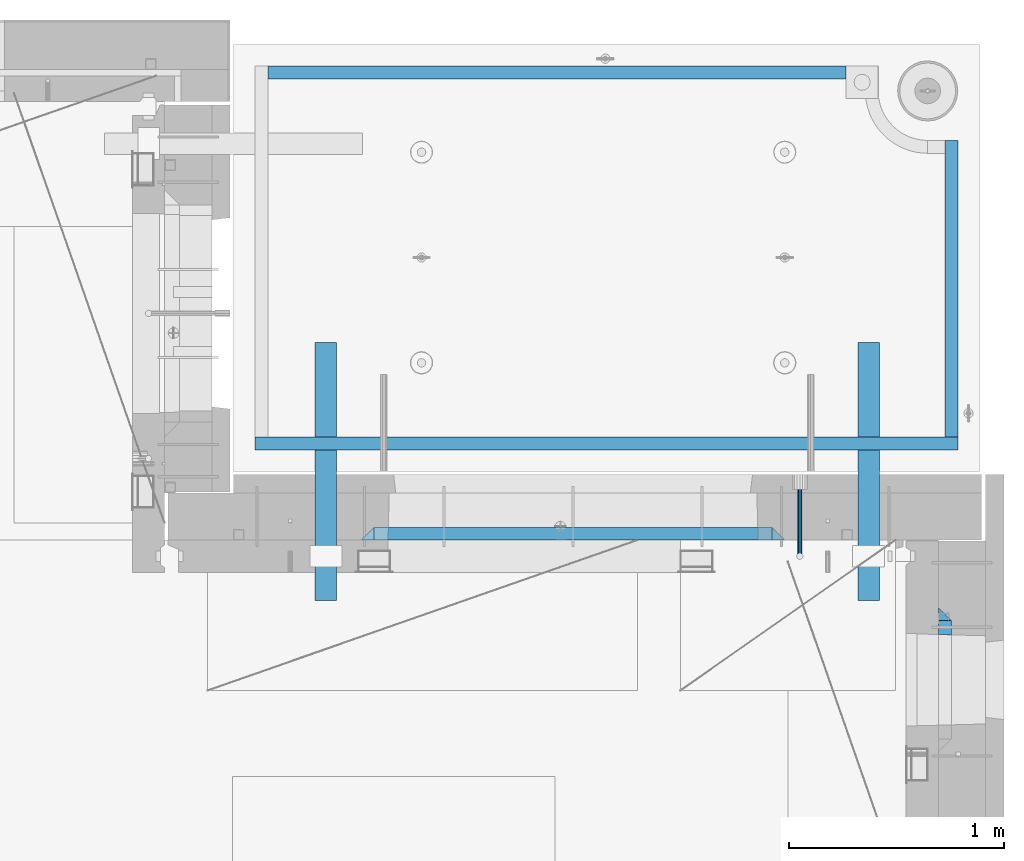
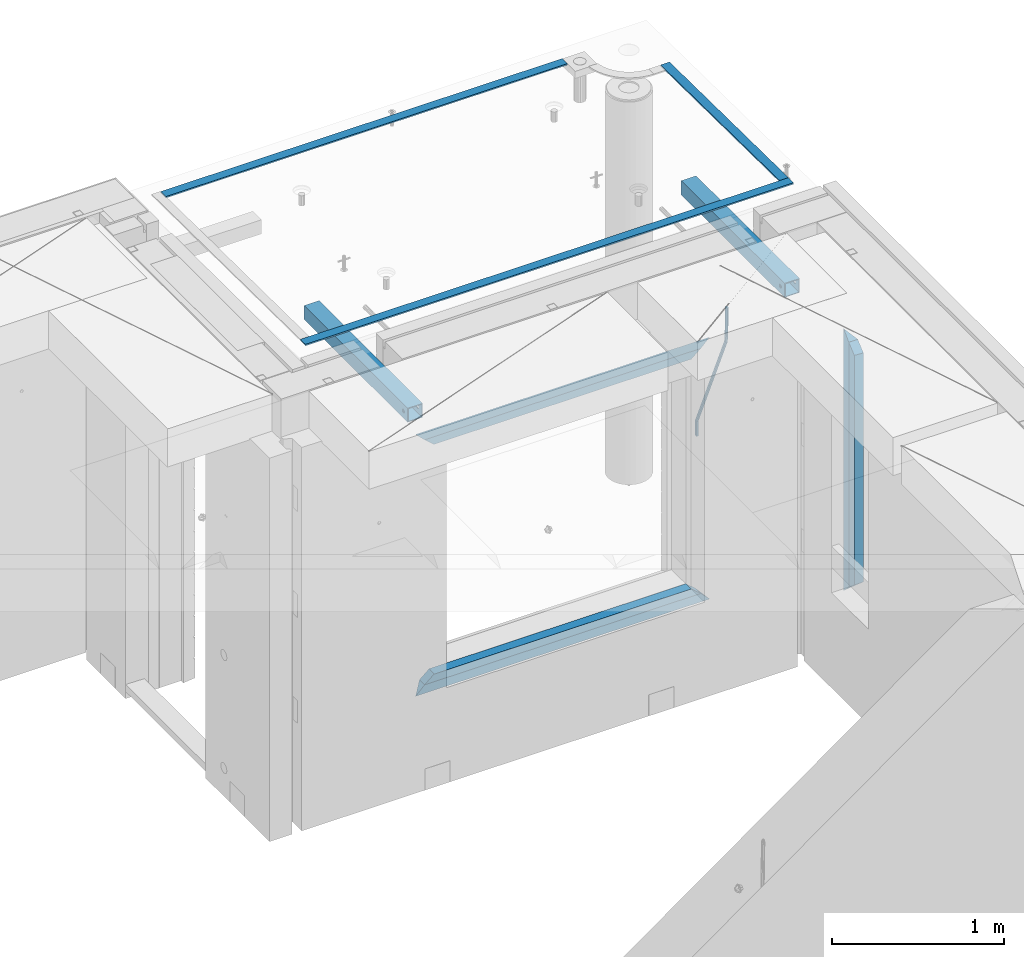
# One storey, part 135 of 349: 12 beams, 5 elements without a shape of their own.
"""IFC2X3 building model written with IfcOpenShell, lengths in millimetres."""

from ifc_helpers import new_model, si_unit, frame, origin_with_axes, place, context, subcontext, project, spatial, faceted_brep, material, type_object, element, aggregate, save


model = new_model("IFC2X3")

# Units and contexts
model_context = context("Model", 3, precision=1e-05, world=origin_with_axes())
body_context = subcontext(model_context, "Body", "Model", "MODEL_VIEW")
ifc_project = project(units=[si_unit("LENGTHUNIT", "METRE", prefix="MILLI"), si_unit("AREAUNIT", "SQUARE_METRE"), si_unit("VOLUMEUNIT", "CUBIC_METRE"), si_unit("MASSUNIT", "GRAM", prefix="KILO"), si_unit("TIMEUNIT", "SECOND"), si_unit("PLANEANGLEUNIT", "RADIAN"), si_unit("SOLIDANGLEUNIT", "STERADIAN"), si_unit("THERMODYNAMICTEMPERATUREUNIT", "DEGREE_CELSIUS"), si_unit("LUMINOUSINTENSITYUNIT", "LUMEN")], contexts=[model_context])

# Site, building, storey
site_placement = place(None, origin_with_axes())
site = spatial("IfcSite", under=ifc_project, at=site_placement, CompositionType="ELEMENT")
building_placement = place(site_placement, origin_with_axes())
building = spatial("IfcBuilding", under=site, at=building_placement, CompositionType="ELEMENT")
storey_placement = place(building_placement, origin_with_axes())
storey = spatial("IfcBuildingStorey", under=building, at=storey_placement, Name="4", CompositionType="ELEMENT", Elevation=0.0)

# Assembly, beam
assembly_1_placement = place(storey_placement, origin_with_axes())
assembly_1 = element("IfcElementAssembly", 1, at=assembly_1_placement, inside=storey, AssemblyPlace="NOTDEFINED", PredefinedType="REINFORCEMENT_UNIT")
ifc_material_1 = material()
beam_type_1 = type_object("IfcBeamType", Name="D20", PredefinedType="NOTDEFINED")
beam_1_placement = place(assembly_1_placement, frame((34415.0000001015, 20504.9951872346, 93407.5), z_axis=(0.000415599999849905, 0.999999913638203, 4.76000000899737e-07), x_axis=(0.0, 0.0, -1.0)))
beam_1 = element("IfcBeam", 2, at=beam_1_placement, type_object=beam_type_1, material=ifc_material_1, Name="JM20", ObjectType="D20", context=body_context, shape_type="Brep", body=[
    faceted_brep([(-0.00060564729210455, -9.99999998165731, 0.0), (-0.000428079845733009, -7.07106779890455, -7.07106781186667), (119.575515501536, -7.07830994756296, -7.07106481604933), (119.575337932896, -10.0072421307195, -3.43332612828817e-06), (0.0, 0.0, -10.0), (119.575943836026, -0.00724214867295814, -9.99999700418266), (0.00042843479604926, 7.07106779888636, -7.07106781186303), (119.57637202373, 7.06382565022977, -7.07106481604933), (0.00060564729210455, 9.99999998166459, 3.63797880709171e-12), (119.576549238118, 9.99275783300072, 2.99581552098971e-06), (0.000428079845733009, 7.07106779890819, 7.07106781186667), (119.576371669405, 7.06382565024978, 7.07107080768037), (0.0, 0.0, 10.0), (119.57594333493, -0.00724214864203532, 10.0000029958155), (-0.000428434810601175, -7.07106779888272, 7.07106781186667), (119.575515147211, -7.07830994754295, 7.07107080768037), (123.00654325854, -7.07836650239551, -6.96786008391246), (122.581588830741, -10.007295666459, 0.0904344953341933), (123.182419066041, -0.00729994480025198, -9.89151006310021), (123.006190977103, 7.06376911688858, -6.96788735351402), (122.581091016109, 9.99270432680532, 0.0903895128230943), (122.156136974867, 7.06377516229986, 7.14867767459873), (121.980261167351, -0.00729139528993983, 10.0723276537792), (122.156489256289, -7.07836045697513, 7.14870494419847), (237.077376207715, -7.07551629289992, -0.0988779924864502), (236.652422053201, -10.0044409119728, 6.95941204931296), (237.253252288647, -0.0044516184279928, -3.02253250974718), (237.077024472936, 7.06661932641327, -0.0989143382521434), (236.651924624995, 9.99555908263574, 6.95936064834314), (236.226970470365, 7.06663446442326, 14.0176506898479), (236.051094389448, -0.0044302100486675, 16.9413052071086), (236.227322205144, -7.07550115488812, 14.0176870356117), (256.715938387759, -7.07353516174771, 4.66794781703175), (253.858321224223, -10.0027051854922, 11.1357628166734), (257.898622435067, -0.00236892073007766, 1.98867362452802), (256.713573090979, 7.0686002544353, 4.66742272414376), (253.85497618909, 9.99729452004976, 11.1350202234971), (250.997359025234, 7.06812449537756, 17.6028352234607), (249.814674977912, -0.00304174564189452, 20.2821094159572), (250.999724322028, -7.07401092080545, 17.6033603163596), (1009.84102825288, -6.93521658215468, 337.477148757798), (1006.98341108896, -9.86438660663771, 343.944963757851), (1011.02371230032, 0.135949658781101, 334.7978745651), (1009.83866295629, 7.20691883402651, 337.476623664521), (1006.98006605446, 10.1356130998429, 343.944221163818), (1004.12244889054, 7.2064430753635, 350.412036163872), (1002.9397648431, 0.135276834424076, 353.091310356571), (1004.12481418712, -6.93569234081951, 350.412561257146), (1010.86335274603, -6.9350288225487, 337.928918327354), (1009.37086865908, -9.86394812736762, 344.999991477531), (1011.48104818776, 0.136033652863262, 334.999973251377), (1010.86211737194, 7.20710680115553, 337.928892551665), (1009.36912157628, 10.1360518725905, 344.9999550252), (1007.87663748935, 7.2071325677698, 352.071028175378), (1007.2589420476, 0.13607009235966, 354.999973251352), (1007.87787286344, -6.93500305593261, 352.071053951067), (1011.98104820926, -6.93502881915083, 337.92891832735), (1011.98104821818, -9.86394811943501, 344.999991477524), (1011.98104818776, 0.136033654382118, 334.999973251375), (1011.98104816627, 7.20710680455704, 337.928892551661), (1011.98104815738, 10.1360518805304, 344.999955025194), (1011.98104816629, 7.20713258024625, 352.071028175369), (1011.98104818778, 0.136070106711486, 354.999973251342), (1011.98104820927, -6.9350030434598, 352.071053951058), (1117.50000002154, -6.93502849844299, 337.928918327156), (1117.50000003044, -9.86394779872717, 344.999991477331), (1117.50000000004, 0.136033975091777, 334.999973251181), (1117.49999997855, 7.20710712526488, 337.928892551467), (1117.49999996964, 10.1360522012383, 344.999955025), (1117.49999997857, 7.20713290095409, 352.071028175174), (1117.50000000006, 0.136070427419327, 354.999973251148), (1117.50000002155, -6.93500272275196, 352.071053950864)], [[[0, 1, 2, 3]], [[1, 4, 5, 2]], [[4, 6, 7, 5]], [[6, 8, 9, 7]], [[8, 10, 11, 9]], [[10, 12, 13, 11]], [[12, 14, 15, 13]], [[14, 0, 3, 15]], [[14, 12, 10, 8, 6, 4, 1, 0]], [[3, 2, 16, 17]], [[2, 5, 18, 16]], [[5, 7, 19, 18]], [[7, 9, 20, 19]], [[9, 11, 21, 20]], [[11, 13, 22, 21]], [[13, 15, 23, 22]], [[15, 3, 17, 23]], [[17, 16, 24, 25]], [[16, 18, 26, 24]], [[18, 19, 27, 26]], [[19, 20, 28, 27]], [[20, 21, 29, 28]], [[21, 22, 30, 29]], [[22, 23, 31, 30]], [[23, 17, 25, 31]], [[25, 24, 32, 33]], [[24, 26, 34, 32]], [[26, 27, 35, 34]], [[27, 28, 36, 35]], [[28, 29, 37, 36]], [[29, 30, 38, 37]], [[30, 31, 39, 38]], [[31, 25, 33, 39]], [[33, 32, 40, 41]], [[32, 34, 42, 40]], [[34, 35, 43, 42]], [[35, 36, 44, 43]], [[36, 37, 45, 44]], [[37, 38, 46, 45]], [[38, 39, 47, 46]], [[39, 33, 41, 47]], [[41, 40, 48, 49]], [[40, 42, 50, 48]], [[42, 43, 51, 50]], [[43, 44, 52, 51]], [[44, 45, 53, 52]], [[45, 46, 54, 53]], [[46, 47, 55, 54]], [[47, 41, 49, 55]], [[49, 48, 56, 57]], [[48, 50, 58, 56]], [[50, 51, 59, 58]], [[51, 52, 60, 59]], [[52, 53, 61, 60]], [[53, 54, 62, 61]], [[54, 55, 63, 62]], [[55, 49, 57, 63]], [[57, 56, 64, 65]], [[56, 58, 66, 64]], [[58, 59, 67, 66]], [[59, 60, 68, 67]], [[60, 61, 69, 68]], [[61, 62, 70, 69]], [[62, 63, 71, 70]], [[63, 57, 65, 71]], [[66, 67, 68, 69, 70, 71, 65, 64]]]),
])

# Assemblies, beams
assembly_2_placement = place(storey_placement, origin_with_axes())
assembly_2 = element("IfcElementAssembly", 3, at=assembly_2_placement, inside=storey, AssemblyPlace="NOTDEFINED", PredefinedType="REINFORCEMENT_UNIT")
assembly_3_placement = place(assembly_2_placement, origin_with_axes())
assembly_3 = element("IfcElementAssembly", 4, at=assembly_3_placement, AssemblyPlace="NOTDEFINED", PredefinedType="NOTDEFINED")
ifc_material_2 = material(Name="Undefined/350")
beam_type_2 = type_object("IfcBeamType", Name="100X100X5", PredefinedType="NOTDEFINED")
beam_2_placement = place(assembly_3_placement, frame((34735.0001432011, 21500.0034426031, 93555.0), z_axis=(0.0, 0.0, 1.0), x_axis=(-2.2242999997242e-05, -0.999999999752625, 0.0)))
beam_2 = element("IfcBeam", 5, at=beam_2_placement, type_object=beam_type_2, material=ifc_material_2, ObjectType="100X100X5", context=body_context, shape_type="Brep", body=[
    faceted_brep([(1143.75108023171, 44.9999999999982, -10.8253175473074), (1143.75107855316, 50.0255964196231, -10.8253175473074), (1139.17576100585, 50.0255948914664, -6.25), (1139.1757626844, 44.9999999999982, -6.25), (1150.00108023171, 44.9999999999982, -12.5), (1150.00107855316, 50.0255985071226, -12.5), (1156.2510802317, 44.9999999999982, -10.8253175473074), (1156.25107855315, 50.0256005946221, -10.8253175473074), (1160.82639777901, 44.9999999999982, -6.25), (1160.82639610046, 50.0256021227788, -6.25), (1162.50108023171, 44.9999999999982, 0.0), (1162.50107855316, 50.0256026821226, 0.0), (1160.82639777901, 44.9999999999982, 6.25), (1160.82639610046, 50.0256021227788, 6.25), (1156.2510802317, 44.9999999999982, 10.8253175473074), (1156.25107855315, 50.0256005946221, 10.8253175473074), (1150.00108023171, 44.9999999999982, 12.5), (1150.00107855316, 50.0255985071226, 12.5), (1143.75108023171, 44.9999999999982, 10.8253175473074), (1143.75107855316, 50.0255964196231, 10.8253175473074), (1139.1757626844, 44.9999999999982, 6.25), (1139.17576100585, 50.0255948914664, 6.25), (1137.5010802317, 44.9999999999982, 0.0), (1137.50107855316, 50.0255943321226, 0.0), (1143.75111195316, -49.9744035792783, -10.8253175473074), (1143.75111029171, -44.9999999999991, -10.8253175473074), (1139.1757927444, -44.9999999999991, -6.25), (1139.17579440585, -49.9744051074349, -6.25), (1150.00111195316, -49.9744014917787, -12.5), (1150.00111029171, -44.9999999999991, -12.5), (1156.25111195316, -49.9743994042774, -10.8253175473074), (1156.25111029171, -44.9999999999991, -10.8253175473074), (1160.82642950046, -49.9743978761207, -6.25), (1160.82642783901, -44.9999999999991, -6.25), (1162.50111195316, -49.9743973167779, 0.0), (1162.50111029171, -44.9999999999991, 0.0), (1160.82642950046, -49.9743978761207, 6.25), (1160.82642783901, -44.9999999999991, 6.25), (1156.25111195316, -49.9743994042774, 10.8253175473074), (1156.25111029171, -44.9999999999991, 10.8253175473074), (1150.00111195316, -49.9744014917787, 12.5), (1150.00111029171, -44.9999999999991, 12.5), (1143.75111195316, -49.9744035792783, 10.8253175473074), (1143.75111029171, -44.9999999999991, 10.8253175473074), (1139.17579440585, -49.9744051074349, 6.25), (1139.1757927444, -44.9999999999991, 6.25), (1137.50111195316, -49.9744056667778, 0.0), (1137.50111029171, -44.9999999999991, 0.0), (1.81898940354586e-12, -50.0000000000009, -50.0), (1.81898940354586e-12, 49.9999999999991, -50.0), (1200.00449189278, 49.9999999999982, -50.0), (1200.00449189278, -50.0000000000009, -50.0), (1.81898940354586e-12, 49.9999999999991, 50.0), (1.81898940354586e-12, -50.0000000000009, 50.0), (1200.00449189278, -50.0000000000009, 50.0), (1200.00449189278, 49.9999999999982, 50.0), (0.0, 44.9999999999991, 45.0), (1.81898940354586e-12, -45.0000000000009, 45.0), (1.81898940354586e-12, -45.0000000000009, -45.0), (0.0, 44.9999999999991, -45.0), (1200.00449189278, 44.9999999999982, -45.0), (1200.00449189278, 44.9999999999982, 45.0), (1200.00449189278, -45.0000000000009, 45.0), (1200.00449189278, -45.0000000000009, -45.0)], [[[0, 1, 2, 3]], [[4, 5, 1, 0]], [[6, 7, 5, 4]], [[8, 9, 7, 6]], [[10, 11, 9, 8]], [[12, 13, 11, 10]], [[14, 15, 13, 12]], [[16, 17, 15, 14]], [[18, 19, 17, 16]], [[20, 21, 19, 18]], [[22, 23, 21, 20]], [[3, 2, 23, 22]], [[24, 25, 26, 27]], [[28, 29, 25, 24]], [[30, 31, 29, 28]], [[32, 33, 31, 30]], [[34, 35, 33, 32]], [[36, 37, 35, 34]], [[38, 39, 37, 36]], [[40, 41, 39, 38]], [[42, 43, 41, 40]], [[44, 45, 43, 42]], [[46, 47, 45, 44]], [[27, 26, 47, 46]], [[48, 49, 50, 51]], [[52, 53, 54, 55]], [[49, 52, 55, 50], [15, 17, 19, 21, 23, 2, 1, 5, 7, 9, 11, 13]], [[48, 53, 52, 49], [56, 57, 58, 59]], [[56, 59, 60, 61], [6, 4, 0, 3, 22, 20, 18, 16, 14, 12, 10, 8]], [[57, 56, 61, 62]], [[58, 57, 62, 63], [39, 41, 43, 45, 47, 26, 25, 29, 31, 33, 35, 37]], [[59, 58, 63, 60]], [[54, 51, 50, 55], [62, 61, 60, 63]], [[53, 48, 51, 54], [30, 28, 24, 27, 46, 44, 42, 40, 38, 36, 34, 32]]]),
])
aggregate(assembly_3, [beam_2])
assembly_4_placement = place(assembly_2_placement, origin_with_axes())
assembly_4 = element("IfcElementAssembly", 6, at=assembly_4_placement, AssemblyPlace="NOTDEFINED", PredefinedType="NOTDEFINED")
beam_3_placement = place(assembly_4_placement, frame((32210.0001432011, 21500.0034426031, 93555.0), z_axis=(0.0, 0.0, 1.0), x_axis=(-2.2242999997242e-05, -0.999999999752625, 0.0)))
beam_3 = element("IfcBeam", 7, at=beam_3_placement, type_object=beam_type_2, material=ifc_material_2, ObjectType="100X100X5", context=body_context, shape_type="Brep", body=[
    faceted_brep([(1143.75108023171, 44.9999999999982, -10.8253175473074), (1143.75107855316, 50.0255964196231, -10.8253175473074), (1139.17576100585, 50.0255948914664, -6.25), (1139.1757626844, 44.9999999999982, -6.25), (1150.00108023171, 44.9999999999982, -12.5), (1150.00107855316, 50.0255985071226, -12.5), (1156.2510802317, 44.9999999999982, -10.8253175473074), (1156.25107855315, 50.0256005946221, -10.8253175473074), (1160.82639777901, 44.9999999999982, -6.25), (1160.82639610046, 50.0256021227788, -6.25), (1162.50108023171, 44.9999999999982, 0.0), (1162.50107855316, 50.0256026821226, 0.0), (1160.82639777901, 44.9999999999982, 6.25), (1160.82639610046, 50.0256021227788, 6.25), (1156.2510802317, 44.9999999999982, 10.8253175473074), (1156.25107855315, 50.0256005946221, 10.8253175473074), (1150.00108023171, 44.9999999999982, 12.5), (1150.00107855316, 50.0255985071226, 12.5), (1143.75108023171, 44.9999999999982, 10.8253175473074), (1143.75107855316, 50.0255964196231, 10.8253175473074), (1139.1757626844, 44.9999999999982, 6.25), (1139.17576100585, 50.0255948914664, 6.25), (1137.5010802317, 44.9999999999982, 0.0), (1137.50107855316, 50.0255943321226, 0.0), (1143.75111195316, -49.9744035792783, -10.8253175473074), (1143.75111029171, -44.9999999999991, -10.8253175473074), (1139.1757927444, -44.9999999999991, -6.25), (1139.17579440585, -49.9744051074349, -6.25), (1150.00111195316, -49.9744014917787, -12.5), (1150.00111029171, -44.9999999999991, -12.5), (1156.25111195316, -49.9743994042774, -10.8253175473074), (1156.25111029171, -44.9999999999991, -10.8253175473074), (1160.82642950046, -49.9743978761207, -6.25), (1160.82642783901, -44.9999999999991, -6.25), (1162.50111195316, -49.9743973167779, 0.0), (1162.50111029171, -44.9999999999991, 0.0), (1160.82642950046, -49.9743978761207, 6.25), (1160.82642783901, -44.9999999999991, 6.25), (1156.25111195316, -49.9743994042774, 10.8253175473074), (1156.25111029171, -44.9999999999991, 10.8253175473074), (1150.00111195316, -49.9744014917787, 12.5), (1150.00111029171, -44.9999999999991, 12.5), (1143.75111195316, -49.9744035792783, 10.8253175473074), (1143.75111029171, -44.9999999999991, 10.8253175473074), (1139.17579440585, -49.9744051074349, 6.25), (1139.1757927444, -44.9999999999991, 6.25), (1137.50111195316, -49.9744056667778, 0.0), (1137.50111029171, -44.9999999999991, 0.0), (1.81898940354586e-12, -50.0000000000009, -50.0), (1.81898940354586e-12, 49.9999999999991, -50.0), (1200.00449189278, 49.9999999999982, -50.0), (1200.00449189278, -50.0000000000009, -50.0), (1.81898940354586e-12, 49.9999999999991, 50.0), (1.81898940354586e-12, -50.0000000000009, 50.0), (1200.00449189278, -50.0000000000009, 50.0), (1200.00449189278, 49.9999999999982, 50.0), (0.0, 44.9999999999991, 45.0), (1.81898940354586e-12, -45.0000000000009, 45.0), (1.81898940354586e-12, -45.0000000000009, -45.0), (0.0, 44.9999999999991, -45.0), (1200.00449189278, 44.9999999999982, -45.0), (1200.00449189278, 44.9999999999982, 45.0), (1200.00449189278, -45.0000000000009, 45.0), (1200.00449189278, -45.0000000000009, -45.0)], [[[0, 1, 2, 3]], [[4, 5, 1, 0]], [[6, 7, 5, 4]], [[8, 9, 7, 6]], [[10, 11, 9, 8]], [[12, 13, 11, 10]], [[14, 15, 13, 12]], [[16, 17, 15, 14]], [[18, 19, 17, 16]], [[20, 21, 19, 18]], [[22, 23, 21, 20]], [[3, 2, 23, 22]], [[24, 25, 26, 27]], [[28, 29, 25, 24]], [[30, 31, 29, 28]], [[32, 33, 31, 30]], [[34, 35, 33, 32]], [[36, 37, 35, 34]], [[38, 39, 37, 36]], [[40, 41, 39, 38]], [[42, 43, 41, 40]], [[44, 45, 43, 42]], [[46, 47, 45, 44]], [[27, 26, 47, 46]], [[48, 49, 50, 51]], [[52, 53, 54, 55]], [[49, 52, 55, 50], [15, 17, 19, 21, 23, 2, 1, 5, 7, 9, 11, 13]], [[48, 53, 52, 49], [56, 57, 58, 59]], [[56, 59, 60, 61], [6, 4, 0, 3, 22, 20, 18, 16, 14, 12, 10, 8]], [[57, 56, 61, 62]], [[58, 57, 62, 63], [39, 41, 43, 45, 47, 26, 25, 29, 31, 33, 35, 37]], [[59, 58, 63, 60]], [[54, 51, 50, 55], [62, 61, 60, 63]], [[53, 48, 51, 54], [30, 28, 24, 27, 46, 44, 42, 40, 38, 36, 34, 32]]]),
])
aggregate(assembly_4, [beam_3])
ifc_material_3 = material(Name="CONCRETE/Concrete_Undefined")
beam_type_3 = type_object("IfcBeamType", PredefinedType="NOTDEFINED")
beam_4_placement = place(assembly_2_placement, frame((31939.9962088653, 22755.0460044164, 93704.8214945677), z_axis=(-6.06120000110142e-05, 1.00000033869885e-09, 0.999999998163093), x_axis=(0.999999998046552, -1.52670000006885e-05, 6.06120000021532e-05)))
beam_4 = element("IfcBeam", 8, at=beam_4_placement, type_object=beam_type_3, material=ifc_material_3, context=body_context, shape_type="Brep", body=[
    faceted_brep([(2.5465851649642e-11, 29.9999999999982, -4.99999999998545), (-2.91038304567337e-11, 29.9999999999982, 5.0), (2689.99575395095, 29.9999999999964, 5.0), (2689.99575395095, 30.0000000000036, -4.99999999998545), (-2.5465851649642e-11, -30.0000000000018, 5.0), (2689.99575395095, -30.0000000000036, 5.00000000001455), (2.72848410531878e-11, -30.0000000000018, -4.99999999998545), (2689.99575395095, -29.9999999999964, -4.99999999998545)], [[[0, 1, 2, 3]], [[1, 4, 5, 2]], [[4, 6, 7, 5]], [[6, 0, 3, 7]], [[5, 7, 3, 2]], [[6, 4, 1, 0]]]),
])
beam_5_placement = place(assembly_2_placement, frame((35120.0586113047, 21059.9283388168, 93725.6638339053), z_axis=(-5.46000002942176e-07, 0.0130421150000144, 0.999914948001093), x_axis=(-4.18520000064741e-05, 0.999914947125351, -0.0130421150016393)))
beam_5 = element("IfcBeam", 9, at=beam_5_placement, type_object=beam_type_3, material=ifc_material_3, context=body_context, shape_type="Brep", body=[
    faceted_brep([(2.5465851649642e-11, 29.9999999999982, -4.99999999998545), (-2.91038304567337e-11, 29.9999999999982, 5.0), (1380.14316164461, 30.0, 5.00000000001455), (1380.1431616447, 29.9999999999927, -5.0), (-2.5465851649642e-11, -30.0000000000018, 5.0), (1380.14316164461, -30.0, 5.00000000001455), (2.72848410531878e-11, -30.0000000000018, -4.99999999998545), (1380.1431616447, -30.0, -5.0)], [[[0, 1, 2, 3]], [[1, 4, 5, 2]], [[4, 6, 7, 5]], [[6, 0, 3, 7]], [[5, 7, 3, 2]], [[6, 4, 1, 0]]]),
])
beam_6_placement = place(assembly_2_placement, frame((31879.9986204165, 21030.068155681, 93725.2788443041), z_axis=(-0.000117617000009658, 3.00000101585662e-09, 0.999999993083121), x_axis=(0.999999992839137, -2.20899999960382e-05, 0.000117616999982089)))
beam_6 = element("IfcBeam", 10, at=beam_6_placement, type_object=beam_type_3, material=ifc_material_3, context=body_context, shape_type="Brep", body=[
    faceted_brep([(2.5465851649642e-11, 29.9999999999982, -4.99999999998545), (-2.91038304567337e-11, 29.9999999999982, 5.0), (3270.06002088557, 30.0, 5.0), (3270.06002088557, 30.0000000000036, -5.0), (-2.5465851649642e-11, -30.0000000000018, 5.0), (3270.06002088557, -30.0, 5.0), (2.72848410531878e-11, -30.0000000000018, -4.99999999998545), (3270.06002088558, -29.9999999999964, -5.0)], [[[0, 1, 2, 3]], [[1, 4, 5, 2]], [[4, 6, 7, 5]], [[6, 0, 3, 7]], [[5, 7, 3, 2]], [[6, 4, 1, 0]]]),
])
aggregate(assembly_2, [assembly_3, assembly_4, beam_4, beam_5, beam_6])

# Beam
ifc_material_4 = material(Name="CONCRETE/C25/30")
beam_type_4 = type_object("IfcBeamType", PredefinedType="NOTDEFINED")
beam_7_placement = place(assembly_1_placement, frame((34345.0010086818, 20609.9951872276, 93145.0), z_axis=(0.0, 0.0, -1.0), x_axis=(-1.0, 3.00000001838171e-08, 0.0)))
beam_7 = element("IfcBeam", 11, at=beam_7_placement, type_object=beam_type_4, material=ifc_material_4, Name="SK", context=body_context, shape_type="Brep", body=[
    faceted_brep([(60.0000000000073, 30.0, 30.0), (0.0, -30.0, -30.0), (60.0000000000073, -30.0, 30.0), (1910.00076293945, 30.0, 30.0), (1970.00076293945, -30.0, -30.0), (1910.00076293945, -30.0, 30.0)], [[[0, 1, 2]], [[1, 0, 3, 4]], [[2, 1, 4, 5]], [[0, 2, 5, 3]], [[4, 3, 5]]]),
])

beam_8_placement = place(assembly_1_placement, frame((34285.0010086818, 20609.9951872276, 93085.0), z_axis=(0.0, 0.0, -1.0), x_axis=(-1.0, 3.00000001838171e-08, 0.0)))
beam_8 = element("IfcBeam", 12, at=beam_8_placement, type_object=beam_type_4, material=ifc_material_4, Name="SK", context=body_context, shape_type="Brep", body=[
    faceted_brep([(64.0548169935064, -30.0, 24.9041288395529), (65.6764386151262, 30.0, 26.294090229203), (0.0, 30.0, -30.0), (0.0, -30.0, -30.0), (64.0548169935064, -30.0, 24.0540540540533), (65.6764386151262, 30.0, 25.6756756756804), (1785.9467088854, -30.0, 24.0540540540533), (1784.32508726378, 30.0, 25.6756756756804), (1784.32508726378, 30.0, 26.2934362810774), (1850.00076293945, 30.0, -30.0), (1850.00076293945, -30.0, -30.0), (1785.9467088854, -30.0, 24.9034748914128)], [[[0, 1, 2, 3]], [[4, 5, 1, 0]], [[6, 7, 5, 4]], [[2, 1, 5, 7, 8, 9]], [[3, 2, 9, 10]], [[6, 4, 0, 3, 10, 11]], [[7, 6, 11, 8]], [[10, 9, 8, 11]]]),
])

beam_9_placement = place(assembly_1_placement, frame((32375.0002457424, 20609.9951872276, 91350.0), z_axis=(0.0, 0.0, 1.0), x_axis=(1.0, 0.0, 0.0)))
beam_9 = element("IfcBeam", 13, at=beam_9_placement, type_object=beam_type_4, material=ifc_material_4, Name="SK", context=body_context, shape_type="Brep", body=[
    faceted_brep([(1970.00076293945, -30.0, -30.0), (1910.00076293945, 30.0, 30.0), (1910.00076293945, -30.0, 30.0), (60.0000000000073, 30.0, 30.0), (60.0000000000073, -30.0, 30.0), (0.0, -30.0, -30.0)], [[[0, 1, 2]], [[3, 4, 2, 1]], [[4, 5, 0, 2]], [[5, 3, 1, 0]], [[3, 5, 4]]]),
])

beam_10_placement = place(assembly_1_placement, frame((32435.0002457424, 20609.9951872276, 91410.0), z_axis=(0.0, 0.0, 1.0), x_axis=(1.0, 0.0, 0.0)))
beam_10 = element("IfcBeam", 14, at=beam_10_placement, type_object=beam_type_4, material=ifc_material_4, Name="SK", context=body_context, shape_type="Brep", body=[
    faceted_brep([(1785.94594594595, -30.0, 24.9041288395238), (1850.00076293945, -30.0, -30.0), (1850.00076293945, 30.0, -30.0), (1784.32432432433, 30.0, 26.2940902291739), (1784.32432432433, 30.0, 25.6756756756804), (1785.94594594595, -30.0, 24.0540540540533), (65.6756756756768, 30.0, 25.6756756756804), (64.0540540540533, -30.0, 24.0540540540533), (65.6756756756768, 30.0, 26.293436281092), (64.0540540540533, -30.0, 24.9034748914419), (0.0, -30.0, -30.0), (0.0, 30.0, -30.0)], [[[0, 1, 2, 3]], [[4, 5, 0, 3]], [[5, 4, 6, 7]], [[7, 6, 8, 9]], [[1, 0, 5, 7, 9, 10]], [[10, 11, 2, 1]], [[6, 4, 3, 2, 11, 8]], [[10, 9, 8, 11]]]),
])

aggregate(assembly_1, [beam_1, beam_7, beam_8, beam_9, beam_10])

# Assembly, beams
assembly_5_placement = place(storey_placement, origin_with_axes())
assembly_5 = element("IfcElementAssembly", 15, at=assembly_5_placement, inside=storey, AssemblyPlace="NOTDEFINED", PredefinedType="REINFORCEMENT_UNIT")
beam_11_placement = place(assembly_5_placement, frame((35090.0, 20234.9999664753, 93175.0), z_axis=(0.0, -1.0, 0.0), x_axis=(0.0, 0.0, -1.0)))
beam_11 = element("IfcBeam", 16, at=beam_11_placement, type_object=beam_type_4, material=ifc_material_4, Name="SK", context=body_context, shape_type="Brep", body=[
    faceted_brep([(60.0000000000073, 30.0, 30.0), (0.0, -30.0, -30.0), (60.0000000000073, -30.0, 30.0), (1795.00000000001, 30.0, 30.0), (1855.0, -30.0, -30.0), (1795.00000000001, -30.0, 30.0)], [[[0, 1, 2]], [[3, 4, 1, 0]], [[4, 5, 2, 1]], [[5, 3, 0, 2]], [[5, 4, 3]]]),
])
beam_type_5 = type_object("IfcBeamType", PredefinedType="NOTDEFINED")
beam_12_placement = place(assembly_5_placement, frame((35090.0, 20169.9999664753, 93115.0), z_axis=(0.0, -1.0, 0.0), x_axis=(0.0, 0.0, -1.0)))
beam_12 = element("IfcBeam", 17, at=beam_12_placement, type_object=beam_type_5, material=ifc_material_4, Name="SK", context=body_context, shape_type="Brep", body=[
    faceted_brep([(0.0, -30.0, -35.0), (54.9034748914273, -30.0, 29.0540540540533), (56.2934362811066, 30.0, 30.6756756756768), (0.0, 30.0, -35.0), (1735.0, 30.0, -35.0), (1735.0, -30.0, -35.0), (1680.09652510857, -30.0, 29.0540540540533), (1678.70656371891, 30.0, 30.6756756756768)], [[[0, 1, 2, 3]], [[4, 5, 0, 3]], [[1, 0, 5, 6]], [[2, 1, 6, 7]], [[3, 2, 7, 4]], [[5, 4, 7, 6]]]),
])
aggregate(assembly_5, [beam_11, beam_12])

save(model, "model.ifc")
